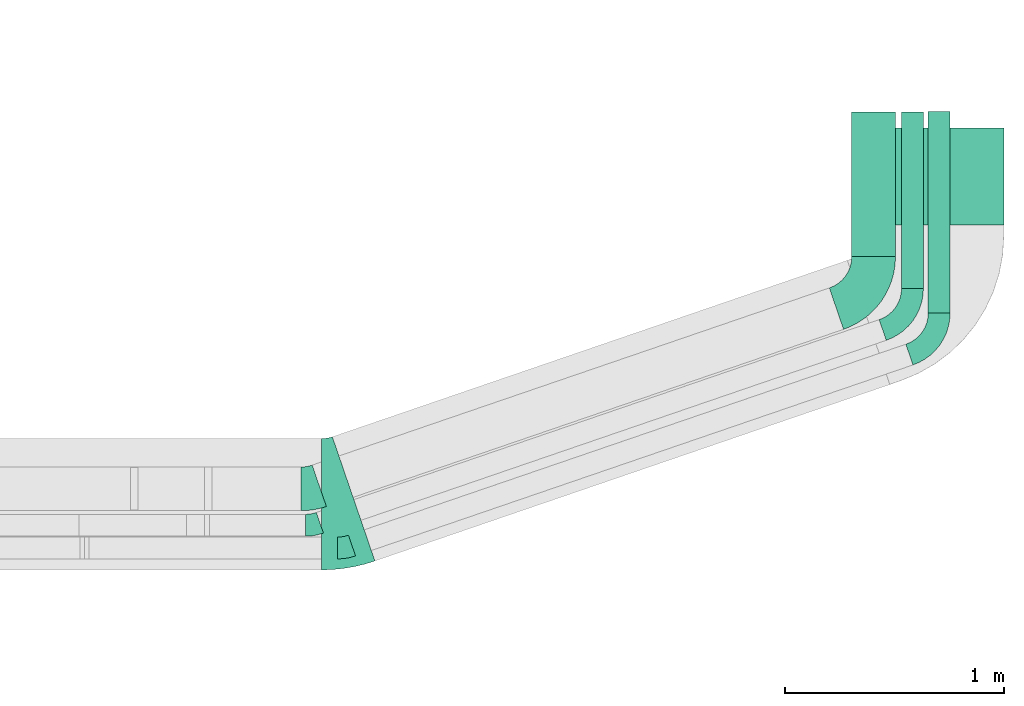
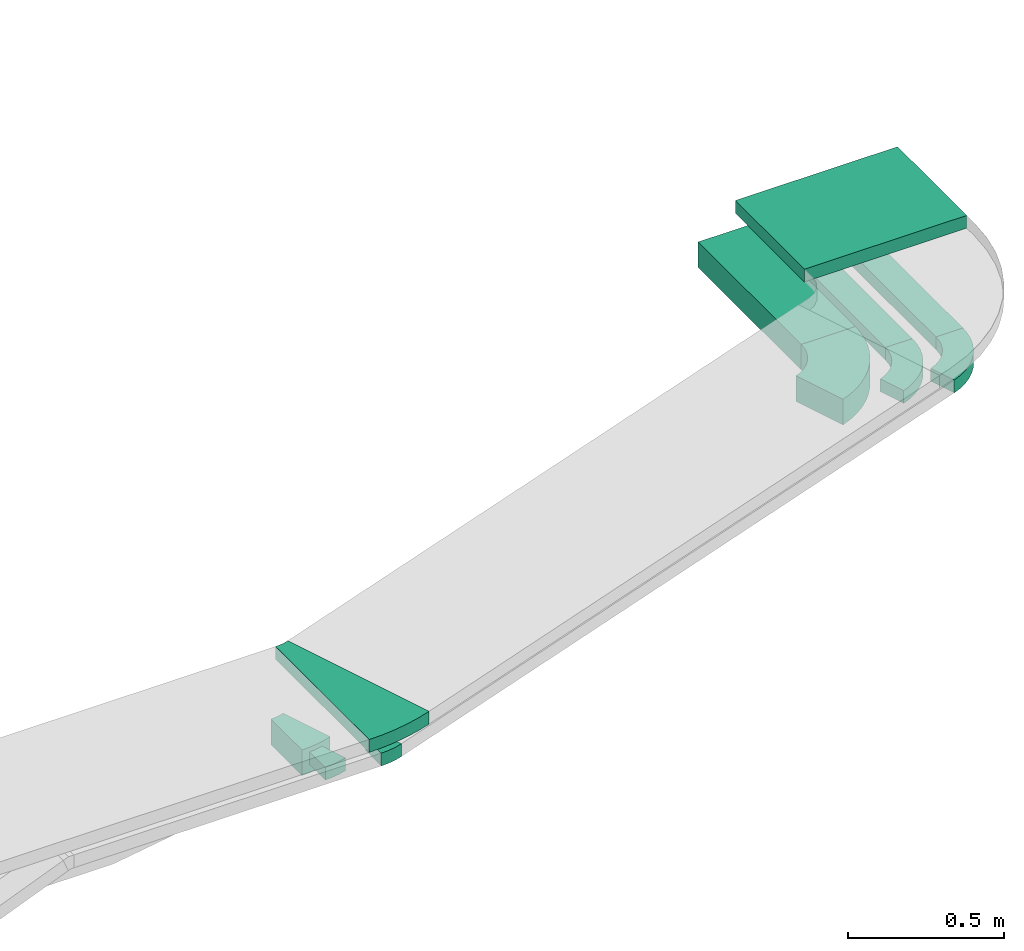
# One storey, part 33 of 38: 7 flow fittings, 4 flow segments.
"""IFC2X3 building model written with IfcOpenShell, lengths in millimetres."""

from ifc_helpers import new_model, entity, si_unit, converted_unit, derived_unit, direction, frame, frame_2d, origin, place, context, subcontext, project, spatial, polyline, circle_curve, parameter, trimmed, segment, composite_curve, rectangle, outline, extrude, source, transform, mapped, material, type_object, type_shapes, element, save


model = new_model("IFC2X3")

# Units and contexts
model_context = context("Model", 3, precision=0.01, world=origin(), true_north=direction((6.12303176911189e-17, 1.0)))
body_context = subcontext(model_context, "Body", "Model", "MODEL_VIEW")
ifc_project = project(units=[si_unit("LENGTHUNIT", "METRE", prefix="MILLI"), si_unit("AREAUNIT", "SQUARE_METRE"), si_unit("VOLUMEUNIT", "CUBIC_METRE"), converted_unit("PLANEANGLEUNIT", "DEGREE", entity("IfcRatioMeasure", 0.0174532925199433), si_unit("PLANEANGLEUNIT", "RADIAN"), dimensions=[0, 0, 0, 0, 0, 0, 0]), si_unit("MASSUNIT", "GRAM", prefix="KILO"), derived_unit("MASSDENSITYUNIT", [(si_unit("MASSUNIT", "GRAM", prefix="KILO"), 1), (si_unit("LENGTHUNIT", "METRE"), -3)]), derived_unit("MOMENTOFINERTIAUNIT", [(si_unit("LENGTHUNIT", "METRE"), 4)]), si_unit("TIMEUNIT", "SECOND"), si_unit("FREQUENCYUNIT", "HERTZ"), si_unit("THERMODYNAMICTEMPERATUREUNIT", "DEGREE_CELSIUS"), derived_unit("THERMALTRANSMITTANCEUNIT", [(si_unit("MASSUNIT", "GRAM", prefix="KILO"), 1), (si_unit("THERMODYNAMICTEMPERATUREUNIT", "KELVIN"), -1), (si_unit("TIMEUNIT", "SECOND"), -3)]), derived_unit("VOLUMETRICFLOWRATEUNIT", [(si_unit("LENGTHUNIT", "METRE"), 3), (si_unit("TIMEUNIT", "SECOND"), -1)]), derived_unit("MASSFLOWRATEUNIT", [(si_unit("MASSUNIT", "GRAM", prefix="KILO"), 1), (si_unit("TIMEUNIT", "SECOND"), -1)]), derived_unit("ROTATIONALFREQUENCYUNIT", [(si_unit("TIMEUNIT", "SECOND"), -1)]), si_unit("ELECTRICCURRENTUNIT", "AMPERE"), si_unit("ELECTRICVOLTAGEUNIT", "VOLT"), si_unit("POWERUNIT", "WATT"), si_unit("FORCEUNIT", "NEWTON", prefix="KILO"), si_unit("ILLUMINANCEUNIT", "LUX"), si_unit("LUMINOUSFLUXUNIT", "LUMEN"), si_unit("LUMINOUSINTENSITYUNIT", "CANDELA"), derived_unit("USERDEFINED", [(si_unit("MASSUNIT", "GRAM", prefix="KILO"), -1), (si_unit("LENGTHUNIT", "METRE"), -2), (si_unit("TIMEUNIT", "SECOND"), 3), (si_unit("LUMINOUSFLUXUNIT", "LUMEN"), 1)]), derived_unit("LINEARVELOCITYUNIT", [(si_unit("LENGTHUNIT", "METRE"), 1), (si_unit("TIMEUNIT", "SECOND"), -1)]), si_unit("PRESSUREUNIT", "PASCAL"), derived_unit("USERDEFINED", [(si_unit("LENGTHUNIT", "METRE"), -2), (si_unit("MASSUNIT", "GRAM", prefix="KILO"), 1), (si_unit("TIMEUNIT", "SECOND"), -2)]), derived_unit("LINEARFORCEUNIT", [(si_unit("MASSUNIT", "GRAM", prefix="KILO"), 1), (si_unit("LENGTHUNIT", "METRE"), 1), (si_unit("TIMEUNIT", "SECOND"), -2), (si_unit("LENGTHUNIT", "METRE"), -1)]), derived_unit("PLANARFORCEUNIT", [(si_unit("MASSUNIT", "GRAM", prefix="KILO"), 1), (si_unit("LENGTHUNIT", "METRE"), 1), (si_unit("TIMEUNIT", "SECOND"), -2), (si_unit("LENGTHUNIT", "METRE"), -2)])], contexts=[model_context])

# Site, building, storey
site_placement = place(None, frame((0.0, -0.00077364408347762, 0.0)))
site = spatial("IfcSite", under=ifc_project, at=site_placement, CompositionType="ELEMENT")
building_placement = place(site_placement, origin())
building = spatial("IfcBuilding", under=site, at=building_placement, CompositionType="ELEMENT")
storey_placement = place(building_placement, frame((0.0, 0.0, 4200.0)))
storey = spatial("IfcBuildingStorey", under=building, at=storey_placement, CompositionType="ELEMENT", Elevation=4200.0)

# Flow segments
cable_carrier_segment_type = type_object("IfcCableCarrierSegmentType", PredefinedType="CABLETRAYSEGMENT")
flow_segment_1_placement = place(storey_placement, frame((67394.0334115348, 9970.29663884081, 2859.5)))
element("IfcFlowSegment", 1, at=flow_segment_1_placement, inside=storey, type_object=cable_carrier_segment_type, context=body_context, shape_type="SweptSolid", body=[
    extrude(rectangle(XDim=443.027180218431, YDim=600.000000000002, at=frame_2d((1.08002495835535e-12, 4.34852154285181e-12), x_axis=(1.0, 0.0))), frame((300.0, 221.513590109222, 0.0), z_axis=(0.0, 0.0, 1.0), x_axis=(0.0, 1.0, 0.0)), (0.0, 0.0, 1.0), 50.0000000000005),
])
flow_segment_2_placement = place(storey_placement, frame((67298.2643637533, 9825.03401443586, 2637.16330868192)))
element("IfcFlowSegment", 2, at=flow_segment_2_placement, inside=storey, type_object=cable_carrier_segment_type, context=body_context, shape_type="SweptSolid", body=[
    extrude(rectangle(XDim=660.390144086837, YDim=200.000000000007, at=frame_2d((-1.10844666778576e-12, 0.0), x_axis=(1.0, 0.0))), frame((100.0, 330.195072043423, 0.0), z_axis=(0.0, 0.0, 1.0), x_axis=(0.0, 1.0, 0.0)), (0.0, 0.0, 1.0), 99.9999999999978),
])
flow_segment_3_placement = place(storey_placement, frame((67525.8345939175, 9680.20633833067, 2683.27515191813)))
element("IfcFlowSegment", 3, at=flow_segment_3_placement, inside=storey, type_object=cable_carrier_segment_type, context=body_context, shape_type="SweptSolid", body=[
    extrude(rectangle(XDim=805.217820192026, YDim=99.9999999999946, at=frame_2d((1.62003743753303e-12, -4.33075797445781e-12), x_axis=(1.0, 0.0))), frame((50.0, 402.608910096011, 0.0), z_axis=(0.0, 0.0, 1.0), x_axis=(0.0, 1.0, 0.0)), (0.0, 0.0, 1.0), 49.9999999999984),
])
flow_segment_4_placement = place(storey_placement, frame((67647.8650594583, 9567.83588765193, 2750.0356453385)))
element("IfcFlowSegment", 4, at=flow_segment_4_placement, inside=storey, type_object=cable_carrier_segment_type, context=body_context, shape_type="SweptSolid", body=[
    extrude(rectangle(XDim=919.515278080052, YDim=99.9999999999426, at=frame_2d((-1.08002495835535e-12, 4.33075797445781e-12), x_axis=(1.0, 0.0))), frame((50.0, 459.75769505135, 0.000515035306324307), z_axis=(0.0, -1.12023218885433e-06, 1.0), x_axis=(0.0, 1.0, 1.12023218885433e-06)), (0.0, 0.0, 1.0), 49.999999999968),
])

# Flow fittings
ifc_material = material()
cable_carrier_fitting_type_1 = type_object("IfcCableCarrierFittingType", Name="470_DKC_S5_Variable Angle Elbow 0-45:-", PredefinedType="NOTDEFINED", material=ifc_material)
shared_shape_1 = source(origin(), body_context, "Body", "SweptSolid", [
    extrude(outline(composite_curve([segment(polyline([(-95.4322270785949, -117.823325600095), (-94.4322270785936, -117.823325600095)]), True, "CONTINUOUS"), segment(trimmed(circle_curve(frame_2d((-94.4322270785941, 132.176674399905), x_axis=(0.0, -1.0)), 250.0), [parameter(0.0)], [parameter(71.0870179252923)], True, "PARAMETER"), True, "CONTINUOUS"), segment(polyline([(142.070758259233, 51.1437309367975), (142.394890033086, 52.0897428781485)]), True, "CONTINUOUS"), segment(polyline([(142.394890033086, 52.0897428781485), (47.7936958979549, 84.502920263392)]), True, "CONTINUOUS"), segment(polyline([(47.7936958979549, 84.502920263392), (47.4695641241024, 83.5569083220405)]), True, "CONTINUOUS"), segment(trimmed(circle_curve(frame_2d((-94.4322270785941, 132.176674399905), x_axis=(0.0, -1.0)), 150.0), [parameter(0.0)], [parameter(71.0870179252923)], True, "PARAMETER"), False, "CONTINUOUS"), segment(polyline([(-94.4322270785936, -17.8233256000949), (-95.4322270785949, -17.8233256000949)]), True, "CONTINUOUS"), segment(polyline([(-95.4322270785949, -17.8233256000949), (-95.4322270785949, -117.823325600095)]), True, "CONTINUOUS")], self_intersect=False)), frame((-48.455657651929, 67.8233256000867, -25.0)), (0.0, 0.0, 1.0), 49.9999999999998),
])
type_shapes(cable_carrier_fitting_type_1, [shared_shape_1])
for number, where, z_axis, x_axis, name in (
    (5, (67575.8345939175, 9536.31845360015, 2708.27515191813), (0.0, 0.0, 1.0), (0.946011941351311, 0.324131773852432, 0.0), "470_DKC_S5_Variable Angle Elbow 0-45:-"),
    (6, (67697.8650594582, 9423.94803092721, 2775.03564533847), (0.0, 0.0, 1.0), (0.946011941351311, 0.324131773852432, 0.0), "470_DKC_S5_Variable Angle Elbow 0-45:-"),
):
    element("IfcFlowFitting", number, at=place(storey_placement, frame(where, z_axis=z_axis, x_axis=x_axis)), inside=storey, type_object=cable_carrier_fitting_type_1, material=ifc_material, Name=name, ObjectType="470_DKC_S5_Variable Angle Elbow 0-45:-", context=body_context, shape_type="MappedRepresentation", body=[
        mapped(shared_shape_1, transform((0.0, 0.0, 0.0), scale=1.0)),
    ])
cable_carrier_fitting_type_2 = type_object("IfcCableCarrierFittingType", Name="470_DKC_S5_Variable Angle Elbow 0-45:-", PredefinedType="NOTDEFINED", material=ifc_material)
shared_shape_2 = source(origin(), body_context, "Body", "SweptSolid", [
    extrude(outline(composite_curve([segment(polyline([(-119.082525612378, -184.720031253784), (-118.082525612376, -184.720031253784)]), True, "CONTINUOUS"), segment(trimmed(circle_curve(frame_2d((-118.082525612377, 165.279968746216), x_axis=(0.0, -1.0)), 350.0), [parameter(0.0)], [parameter(71.0870179252923)], True, "PARAMETER"), True, "CONTINUOUS"), segment(polyline([(213.021653860582, 51.833847897865), (213.345785634434, 52.7798598392169)]), True, "CONTINUOUS"), segment(polyline([(213.345785634434, 52.779859839217), (24.1433973641718, 117.606214609702)]), True, "CONTINUOUS"), segment(polyline([(24.1433973641718, 117.606214609702), (23.8192655903196, 116.660202668351)]), True, "CONTINUOUS"), segment(trimmed(circle_curve(frame_2d((-118.082525612377, 165.279968746216), x_axis=(0.0, -1.0)), 150.0), [parameter(0.0)], [parameter(71.0870179252923)], True, "PARAMETER"), False, "CONTINUOUS"), segment(polyline([(-118.082525612376, 15.279968746216), (-119.082525612378, 15.279968746216)]), True, "CONTINUOUS"), segment(polyline([(-119.082525612378, 15.279968746216), (-119.082525612378, -184.720031253784)]), True, "CONTINUOUS")], self_intersect=False)), frame((-60.5273303007794, 84.7200312537758, -50.0)), (0.0, 0.0, 1.0), 100.0),
])
type_shapes(cable_carrier_fitting_type_2, [shared_shape_2])
flow_fitting_1_placement = place(storey_placement, frame((67398.2643637532, 9645.4241585227, 2687.16330868192), z_axis=(0.0, 0.0, 1.0), x_axis=(0.946011941351309, 0.324131773852437, 0.0)))
element("IfcFlowFitting", 7, at=flow_fitting_1_placement, inside=storey, type_object=cable_carrier_fitting_type_2, material=ifc_material, Name="470_DKC_S5_Variable Angle Elbow 0-45:-", ObjectType="470_DKC_S5_Variable Angle Elbow 0-45:-", context=body_context, shape_type="MappedRepresentation", body=[
    mapped(shared_shape_2, transform((0.0, 0.0, 0.0), scale=1.0)),
])
cable_carrier_fitting_type_3 = type_object("IfcCableCarrierFittingType", Name="470_DKC_S5_Variable Angle Elbow 0-45:-", PredefinedType="NOTDEFINED", material=ifc_material)
shared_shape_3 = source(origin(), body_context, "Body", "SweptSolid", [
    extrude(outline(composite_curve([segment(polyline([(-41.5029747168925, -106.829540274549), (-40.5029747168911, -106.829540274549)]), True, "CONTINUOUS"), segment(trimmed(circle_curve(frame_2d((-40.5029747168917, 243.17045972545), x_axis=(0.0, -1.0)), 350.0), [parameter(0.0)], [parameter(18.9129820747075)], True, "PARAMETER"), True, "CONTINUOUS"), segment(polyline([(72.9431461314589, -87.9337197475081), (73.88915807281, -87.6095879736557)]), True, "CONTINUOUS"), segment(polyline([(73.88915807281, -87.6095879736558), (9.06280330232431, 101.592800296606)]), True, "CONTINUOUS"), segment(polyline([(9.06280330232433, 101.592800296606), (8.11679136097286, 101.268668522754)]), True, "CONTINUOUS"), segment(trimmed(circle_curve(frame_2d((-40.5029747168917, 243.17045972545), x_axis=(0.0, -1.0)), 150.0), [parameter(0.0)], [parameter(18.9129820747075)], True, "PARAMETER"), False, "CONTINUOUS"), segment(polyline([(-40.5029747168911, 93.1704597254507), (-41.5029747168925, 93.1704597254507)]), True, "CONTINUOUS"), segment(polyline([(-41.5029747168925, 93.1704597254507), (-41.5029747168925, -106.829540274549)]), True, "CONTINUOUS")], self_intersect=False)), frame((-1.13754235353246, 6.82954027454111, -50.0)), (0.0, 0.0, 1.0), 100.0),
])
type_shapes(cable_carrier_fitting_type_3, [shared_shape_3])
flow_fitting_2_placement = place(storey_placement, frame((64825.1118832777, 8763.78573364408, 2687.16330868192)))
element("IfcFlowFitting", 8, at=flow_fitting_2_placement, inside=storey, type_object=cable_carrier_fitting_type_3, material=ifc_material, Name="470_DKC_S5_Variable Angle Elbow 0-45:-", ObjectType="470_DKC_S5_Variable Angle Elbow 0-45:-", context=body_context, shape_type="MappedRepresentation", body=[
    mapped(shared_shape_3, transform((0.0, 0.0, 0.0), scale=1.0)),
])
cable_carrier_fitting_type_4 = type_object("IfcCableCarrierFittingType", Name="470_DKC_S5_Variable Angle Elbow 0-45:-", PredefinedType="NOTDEFINED", material=ifc_material)
shared_shape_4 = source(origin(), body_context, "Body", "SweptSolid", [
    extrude(outline(composite_curve([segment(polyline([(-33.3996807000127, -55.4798389221258), (-32.3996807000114, -55.4798389221258)]), True, "CONTINUOUS"), segment(trimmed(circle_curve(frame_2d((-32.3996807000119, 194.520161077874), x_axis=(0.0, -1.0)), 250.0), [parameter(0.0)], [parameter(18.9129822744004)], True, "PARAMETER"), True, "CONTINUOUS"), segment(polyline([(48.6332635873792, -41.9828239775297), (49.5792755276009, -41.6586922003801)]), True, "CONTINUOUS"), segment(polyline([(49.5792755276009, -41.6586922003801), (17.1660978126443, 52.9425018217813)]), True, "CONTINUOUS"), segment(polyline([(17.1660978126443, 52.9425018217813), (16.2200858724228, 52.6183700446317)]), True, "CONTINUOUS"), segment(trimmed(circle_curve(frame_2d((-32.3996807000119, 194.520161077874), x_axis=(0.0, -1.0)), 150.0), [parameter(0.0)], [parameter(18.9129822744004)], True, "PARAMETER"), False, "CONTINUOUS"), segment(polyline([(-32.3996807000114, 44.520161077874), (-33.3996807000127, 44.520161077874)]), True, "CONTINUOUS"), segment(polyline([(-33.3996807000127, 44.520161077874), (-33.3996807000127, -55.4798389221258)]), True, "CONTINUOUS")], self_intersect=False)), frame((-0.912733314524626, 5.47983892211778, -25.0)), (0.0, 0.0, 1.0), 50.0000000000001),
])
type_shapes(cable_carrier_fitting_type_4, [shared_shape_4])
flow_fitting_3_placement = place(storey_placement, frame((64835.6444861709, 8597.44797903924, 2708.27515191813), z_axis=(4.88705511631072e-05, -0.000142633733284561, 0.999999988633644), x_axis=(1.0, 0.0, -4.88705516602278e-05)))
element("IfcFlowFitting", 9, at=flow_fitting_3_placement, inside=storey, type_object=cable_carrier_fitting_type_4, material=ifc_material, Name="470_DKC_S5_Variable Angle Elbow 0-45:-", ObjectType="470_DKC_S5_Variable Angle Elbow 0-45:-", context=body_context, shape_type="MappedRepresentation", body=[
    mapped(shared_shape_4, transform((0.0, 0.0, 0.0), scale=1.0)),
])
cable_carrier_fitting_type_5 = type_object("IfcCableCarrierFittingType", Name="470_DKC_S5_Variable Angle Elbow 0-45:-", PredefinedType="NOTDEFINED", material=ifc_material)
shared_shape_5 = source(origin(), body_context, "Body", "SweptSolid", [
    extrude(outline(composite_curve([segment(polyline([(-33.3996805885598, -55.4798388836272), (-32.3996805885585, -55.4798388836272)]), True, "CONTINUOUS"), segment(trimmed(circle_curve(frame_2d((-32.399680588559, 194.520161116372), x_axis=(0.0, -1.0)), 250.0), [parameter(0.0)], [parameter(18.9129822068405)], True, "PARAMETER"), True, "CONTINUOUS"), segment(polyline([(48.633263419961, -41.9828240345805), (49.5792753605646, -41.6586922585465)]), True, "CONTINUOUS"), segment(polyline([(49.5792753605646, -41.6586922585465), (17.166097757157, 52.9425018018349)]), True, "CONTINUOUS"), segment(polyline([(17.166097757157, 52.9425018018349), (16.220085816553, 52.6183700258007)]), True, "CONTINUOUS"), segment(trimmed(circle_curve(frame_2d((-32.399680588559, 194.520161116372), x_axis=(0.0, -1.0)), 150.0), [parameter(0.0)], [parameter(18.9129822068405)], True, "PARAMETER"), False, "CONTINUOUS"), segment(polyline([(-32.3996805885585, 44.5201611163727), (-33.3996805885598, 44.5201611163727)]), True, "CONTINUOUS"), segment(polyline([(-33.3996805885598, 44.5201611163727), (-33.3996805885598, -55.4798388836272)]), True, "CONTINUOUS")], self_intersect=False)), frame((-0.912733304791814, 5.47983888361911, -25.0)), (0.0, 0.0, 1.0), 50.0000000000001),
])
type_shapes(cable_carrier_fitting_type_5, [shared_shape_5])
flow_fitting_4_placement = place(storey_placement, frame((64982.4013482912, 8493.5495538475, 2775.03564533847), z_axis=(3.97531317755956e-05, -0.000116023606445159, 0.999999992479106), x_axis=(1.0, 0.0, -3.97531320431636e-05)))
element("IfcFlowFitting", 10, at=flow_fitting_4_placement, inside=storey, type_object=cable_carrier_fitting_type_5, material=ifc_material, Name="470_DKC_S5_Variable Angle Elbow 0-45:-", ObjectType="470_DKC_S5_Variable Angle Elbow 0-45:-", context=body_context, shape_type="MappedRepresentation", body=[
    mapped(shared_shape_5, transform((0.0, 0.0, 0.0), scale=1.0)),
])
cable_carrier_fitting_type_6 = type_object("IfcCableCarrierFittingType", Name="470_DKC_S5_Variable Angle Elbow 0-45:-", PredefinedType="NOTDEFINED", material=ifc_material)
shared_shape_6 = source(origin(), body_context, "Body", "SweptSolid", [
    extrude(outline(composite_curve([segment(polyline([(-73.9161521015883, -312.228346139224), (-72.9161521015864, -312.228346139224)]), True, "CONTINUOUS"), segment(trimmed(circle_curve(frame_2d((-72.916152101562, 437.771653860776), x_axis=(0.0, -1.0)), 750.0), [parameter(0.0)], [parameter(18.9129820745573)], True, "PARAMETER"), True, "CONTINUOUS"), segment(polyline([(170.182678285876, -271.737302153353), (171.128690227229, -271.413170379503)]), True, "CONTINUOUS"), segment(polyline([(171.128690227229, -271.413170379503), (-23.3503740827236, 296.1939944318)]), True, "CONTINUOUS"), segment(polyline([(-23.3503740827237, 296.1939944318), (-24.2963860240745, 295.86986265795)]), True, "CONTINUOUS"), segment(trimmed(circle_curve(frame_2d((-72.916152101562, 437.771653860776), x_axis=(0.0, -1.0)), 150.0), [parameter(0.0)], [parameter(18.9129820745573)], True, "PARAMETER"), False, "CONTINUOUS"), segment(polyline([(-72.9161521015661, 287.771653860776), (-73.916152101568, 287.771653860776)]), True, "CONTINUOUS"), segment(polyline([(-73.916152101568, 287.771653860776), (-73.9161521015883, -312.228346139224)]), True, "CONTINUOUS")], self_intersect=False)), frame((-2.03677862458775, 12.2283461392181, -25.0)), (0.0, 0.0, 1.0), 50.0000000000028),
])
type_shapes(cable_carrier_fitting_type_6, [shared_shape_6])
flow_fitting_5_placement = place(storey_placement, frame((64950.5466675425, 8693.3238190595, 2884.52170146582)))
element("IfcFlowFitting", 11, at=flow_fitting_5_placement, inside=storey, type_object=cable_carrier_fitting_type_6, material=ifc_material, Name="470_DKC_S5_Variable Angle Elbow 0-45:-", ObjectType="470_DKC_S5_Variable Angle Elbow 0-45:-", context=body_context, shape_type="MappedRepresentation", body=[
    mapped(shared_shape_6, transform((0.0, 0.0, 0.0), scale=1.0)),
])

save(model, "model.ifc")
